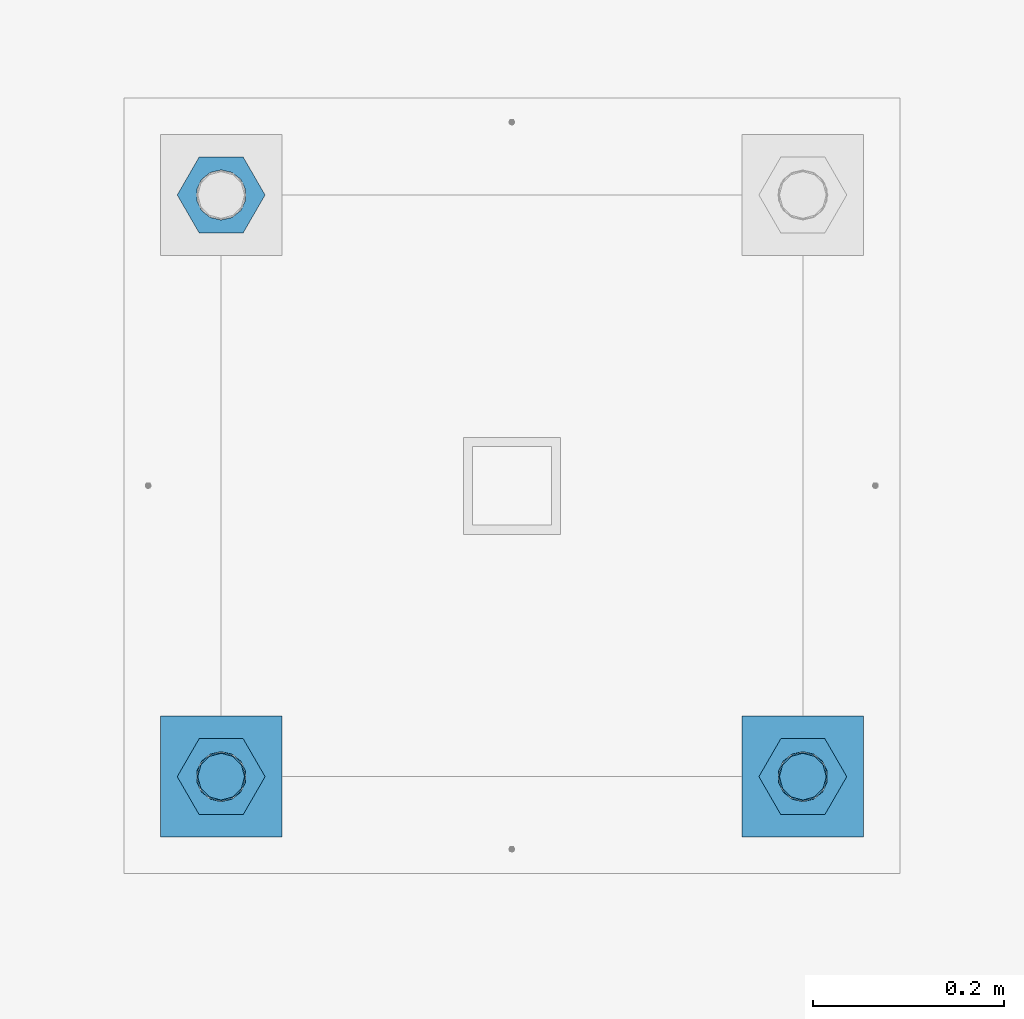
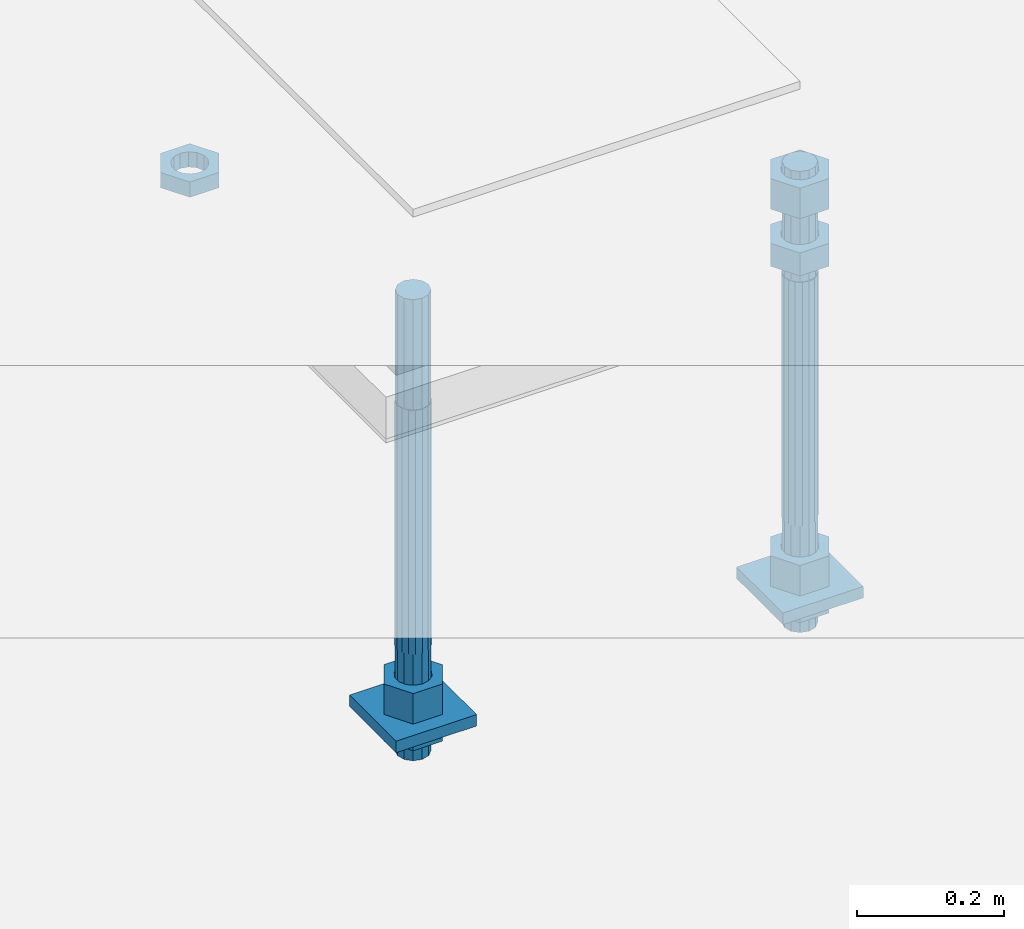
# One storey, part 2743 of 3843: 11 beams, 1 element without a shape of its own.
"""IFC2X3 building model written with IfcOpenShell, lengths in millimetres."""

from ifc_helpers import new_model, si_unit, frame, origin_with_axes, place, context, subcontext, project, spatial, faceted_brep, material, type_object, element, aggregate, save


model = new_model("IFC2X3")

# Units and contexts
model_context = context("Model", 3, precision=1e-05, world=origin_with_axes())
body_context = subcontext(model_context, "Body", "Model", "MODEL_VIEW")
ifc_project = project(units=[si_unit("LENGTHUNIT", "METRE", prefix="MILLI"), si_unit("AREAUNIT", "SQUARE_METRE"), si_unit("VOLUMEUNIT", "CUBIC_METRE"), si_unit("MASSUNIT", "GRAM", prefix="KILO"), si_unit("TIMEUNIT", "SECOND"), si_unit("PLANEANGLEUNIT", "RADIAN"), si_unit("SOLIDANGLEUNIT", "STERADIAN"), si_unit("THERMODYNAMICTEMPERATUREUNIT", "DEGREE_CELSIUS"), si_unit("LUMINOUSINTENSITYUNIT", "LUMEN")], contexts=[model_context])

# Site, building, storey
site_placement = place(None, origin_with_axes())
site = spatial("IfcSite", under=ifc_project, at=site_placement, CompositionType="ELEMENT")
building_placement = place(site_placement, origin_with_axes())
building = spatial("IfcBuilding", under=site, at=building_placement, Name="Undefined", CompositionType="ELEMENT")
storey_placement = place(building_placement, origin_with_axes())
storey = spatial("IfcBuildingStorey", under=building, at=storey_placement, Name="Undefined", CompositionType="ELEMENT", Elevation=0.0)

# Assembly, beams
assembly_placement = place(storey_placement, origin_with_axes())
assembly = element("IfcElementAssembly", 1, at=assembly_placement, inside=storey, Name="TEMPLATE", AssemblyPlace="NOTDEFINED", PredefinedType="RIGID_FRAME")
ifc_material_1 = material(Name="STEEL/A36")
beam_type_1 = type_object("IfcBeamType", PredefinedType="NOTDEFINED")
beam_1_placement = place(assembly_placement, frame((111734.6, 41503.6000015259, 29244.925), z_axis=(1.0, 0.0, 0.0), x_axis=(0.0, 1.0, 0.0)))
beam_1 = element("IfcBeam", 2, at=beam_1_placement, type_object=beam_type_1, material=ifc_material_1, Name="WASHER_PLATE", context=body_context, shape_type="Brep", body=[
    faceted_brep([(0.0, 9.52500000000146, -63.5), (0.0, 9.52500000000146, 63.5), (127.0, 9.52500000000146, 63.5), (127.0, 9.52500000000146, -63.5), (0.0, -9.52500000000146, 63.5), (127.0, -9.52500000000146, 63.5), (0.0, -9.52500000000146, -63.5), (127.0, -9.52500000000146, -63.5)], [[[0, 1, 2, 3]], [[1, 4, 5, 2]], [[4, 6, 7, 5]], [[6, 0, 3, 7]], [[5, 7, 3, 2]], [[6, 4, 1, 0]]]),
])
beam_2_placement = place(assembly_placement, frame((112344.2, 41503.6000015259, 29244.925), z_axis=(1.0, 0.0, 0.0), x_axis=(0.0, 1.0, 0.0)))
beam_2 = element("IfcBeam", 3, at=beam_2_placement, type_object=beam_type_1, material=ifc_material_1, Name="WASHER_PLATE", context=body_context, shape_type="Brep", body=[
    faceted_brep([(0.0, 9.52500000000146, -63.5), (0.0, 9.52500000000146, 63.5), (127.0, 9.52500000000146, 63.5), (127.0, 9.52500000000146, -63.5), (0.0, -9.52500000000146, 63.5), (127.0, -9.52500000000146, 63.5), (0.0, -9.52500000000146, -63.5), (127.0, -9.52500000000146, -63.5)], [[[0, 1, 2, 3]], [[1, 4, 5, 2]], [[4, 6, 7, 5]], [[6, 0, 3, 7]], [[5, 7, 3, 2]], [[6, 4, 1, 0]]]),
])
beam_type_2 = type_object("IfcBeamType", Name="2_HALF_NUT", PredefinedType="NOTDEFINED")
beam_3_placement = place(assembly_placement, frame((111734.6, 42176.7000015259, 29787.85), z_axis=(0.0, 1.0, 0.0), x_axis=(0.0, 0.0, -1.0)))
beam_3 = element("IfcBeam", 4, at=beam_3_placement, type_object=beam_type_2, material=ifc_material_1, Name="NUT", ObjectType="2_HALF_NUT", context=body_context, shape_type="Brep", body=[
    faceted_brep([(0.0, -46.0369987487793, 0.0), (0.0, -23.0184993743896, -39.869213104248), (25.4000000000015, -23.0184993743896, -39.869213104248), (25.4000000000015, -46.0369987487793, 0.0), (0.0, 23.0184993743896, -39.869213104248), (25.4000000000015, 23.0184993743896, -39.869213104248), (0.0, 46.0369987487793, 0.0), (25.4000000000015, 46.0369987487793, 0.0), (0.0, 23.0184993743896, 39.869213104248), (25.4000000000015, 23.0184993743896, 39.869213104248), (0.0, -23.0184993743896, 39.869213104248), (25.4000000000015, -23.0184993743896, 39.869213104248), (0.0, 0.0, 26.1940002441406), (0.0, 11.3650617044477, 23.5999013092805), (25.4000000000015, 11.3650617044477, 23.5999013092805), (25.4000000000015, 0.0, 26.1940002441406), (0.0, 20.4791109456419, 16.3316083006721), (25.4000000000015, 20.4791109456419, 16.3316083006721), (0.0, 25.5370200498292, 5.82867859874386), (25.4000000000015, 25.5370200498292, 5.82867859874386), (0.0, 25.5370200498292, -5.82867859874386), (25.4000000000015, 25.5370200498292, -5.82867859874386), (0.0, 20.4791109456419, -16.3316083006721), (25.4000000000015, 20.4791109456419, -16.3316083006721), (0.0, 11.3650617044477, -23.5999013092805), (25.4000000000015, 11.3650617044477, -23.5999013092805), (0.0, 0.0, -26.1940002441406), (25.4000000000015, 0.0, -26.1940002441406), (0.0, -11.3650617044477, -23.5999013092805), (25.4000000000015, -11.3650617044477, -23.5999013092805), (0.0, -20.4791109456419, -16.3316083006721), (25.4000000000015, -20.4791109456419, -16.3316083006721), (0.0, -25.5370200498292, -5.82867859874386), (25.4000000000015, -25.5370200498292, -5.82867859874386), (0.0, -25.5370200498292, 5.82867859874386), (25.4000000000015, -25.5370200498292, 5.82867859874386), (0.0, -20.4791109456419, 16.3316083006721), (25.4000000000015, -20.4791109456419, 16.3316083006721), (0.0, -11.3650617044477, 23.5999013092805), (25.4000000000015, -11.3650617044477, 23.5999013092805)], [[[0, 1, 2, 3]], [[1, 4, 5, 2]], [[4, 6, 7, 5]], [[6, 8, 9, 7]], [[8, 10, 11, 9]], [[10, 0, 3, 11]], [[12, 13, 14, 15]], [[13, 16, 17, 14]], [[16, 18, 19, 17]], [[18, 20, 21, 19]], [[20, 22, 23, 21]], [[22, 24, 25, 23]], [[24, 26, 27, 25]], [[26, 28, 29, 27]], [[28, 30, 31, 29]], [[30, 32, 33, 31]], [[32, 34, 35, 33]], [[34, 36, 37, 35]], [[36, 38, 39, 37]], [[38, 12, 15, 39]], [[5, 7, 9, 11, 3, 2], [17, 19, 21, 23, 25, 27, 29, 31, 33, 35, 37, 39, 15, 14]], [[10, 8, 6, 4, 1, 0], [38, 36, 34, 32, 30, 28, 26, 24, 22, 20, 18, 16, 13, 12]]]),
])
beam_4_placement = place(assembly_placement, frame((111734.6, 41567.1000015259, 29235.4), z_axis=(0.0, 1.0, 0.0), x_axis=(0.0, 0.0, -1.0)))
beam_4 = element("IfcBeam", 5, at=beam_4_placement, type_object=beam_type_2, material=ifc_material_1, Name="NUT", ObjectType="2_HALF_NUT", context=body_context, shape_type="Brep", body=[
    faceted_brep([(0.0, -46.0369987487793, 0.0), (0.0, -23.0184993743896, -39.869213104248), (25.4000000000015, -23.0184993743896, -39.869213104248), (25.4000000000015, -46.0369987487793, 0.0), (0.0, 23.0184993743896, -39.869213104248), (25.4000000000015, 23.0184993743896, -39.869213104248), (0.0, 46.0369987487793, 0.0), (25.4000000000015, 46.0369987487793, 0.0), (0.0, 23.0184993743896, 39.869213104248), (25.4000000000015, 23.0184993743896, 39.869213104248), (0.0, -23.0184993743896, 39.869213104248), (25.4000000000015, -23.0184993743896, 39.869213104248), (0.0, 0.0, 26.1940002441406), (0.0, 11.3650617044477, 23.5999013092805), (25.4000000000015, 11.3650617044477, 23.5999013092805), (25.4000000000015, 0.0, 26.1940002441406), (0.0, 20.4791109456419, 16.3316083006721), (25.4000000000015, 20.4791109456419, 16.3316083006721), (0.0, 25.5370200498292, 5.82867859874386), (25.4000000000015, 25.5370200498292, 5.82867859874386), (0.0, 25.5370200498292, -5.82867859874386), (25.4000000000015, 25.5370200498292, -5.82867859874386), (0.0, 20.4791109456419, -16.3316083006721), (25.4000000000015, 20.4791109456419, -16.3316083006721), (0.0, 11.3650617044477, -23.5999013092805), (25.4000000000015, 11.3650617044477, -23.5999013092805), (0.0, 0.0, -26.1940002441406), (25.4000000000015, 0.0, -26.1940002441406), (0.0, -11.3650617044477, -23.5999013092805), (25.4000000000015, -11.3650617044477, -23.5999013092805), (0.0, -20.4791109456419, -16.3316083006721), (25.4000000000015, -20.4791109456419, -16.3316083006721), (0.0, -25.5370200498292, -5.82867859874386), (25.4000000000015, -25.5370200498292, -5.82867859874386), (0.0, -25.5370200498292, 5.82867859874386), (25.4000000000015, -25.5370200498292, 5.82867859874386), (0.0, -20.4791109456419, 16.3316083006721), (25.4000000000015, -20.4791109456419, 16.3316083006721), (0.0, -11.3650617044477, 23.5999013092805), (25.4000000000015, -11.3650617044477, 23.5999013092805)], [[[0, 1, 2, 3]], [[1, 4, 5, 2]], [[4, 6, 7, 5]], [[6, 8, 9, 7]], [[8, 10, 11, 9]], [[10, 0, 3, 11]], [[12, 13, 14, 15]], [[13, 16, 17, 14]], [[16, 18, 19, 17]], [[18, 20, 21, 19]], [[20, 22, 23, 21]], [[22, 24, 25, 23]], [[24, 26, 27, 25]], [[26, 28, 29, 27]], [[28, 30, 31, 29]], [[30, 32, 33, 31]], [[32, 34, 35, 33]], [[34, 36, 37, 35]], [[36, 38, 39, 37]], [[38, 12, 15, 39]], [[5, 7, 9, 11, 3, 2], [17, 19, 21, 23, 25, 27, 29, 31, 33, 35, 37, 39, 15, 14]], [[10, 8, 6, 4, 1, 0], [38, 36, 34, 32, 30, 28, 26, 24, 22, 20, 18, 16, 13, 12]]]),
])
beam_5_placement = place(assembly_placement, frame((112344.2, 41567.1000015259, 29235.4), z_axis=(0.0, 1.0, 0.0), x_axis=(0.0, 0.0, -1.0)))
beam_5 = element("IfcBeam", 6, at=beam_5_placement, type_object=beam_type_2, material=ifc_material_1, Name="NUT", ObjectType="2_HALF_NUT", context=body_context, shape_type="Brep", body=[
    faceted_brep([(0.0, -46.0369987487793, 0.0), (0.0, -23.0184993743896, -39.869213104248), (25.4000000000015, -23.0184993743896, -39.869213104248), (25.4000000000015, -46.0369987487793, 0.0), (0.0, 23.0184993743896, -39.869213104248), (25.4000000000015, 23.0184993743896, -39.869213104248), (0.0, 46.0369987487793, 0.0), (25.4000000000015, 46.0369987487793, 0.0), (0.0, 23.0184993743896, 39.869213104248), (25.4000000000015, 23.0184993743896, 39.869213104248), (0.0, -23.0184993743896, 39.869213104248), (25.4000000000015, -23.0184993743896, 39.869213104248), (0.0, 0.0, 26.1940002441406), (0.0, 11.3650617044477, 23.5999013092805), (25.4000000000015, 11.3650617044477, 23.5999013092805), (25.4000000000015, 0.0, 26.1940002441406), (0.0, 20.4791109456419, 16.3316083006721), (25.4000000000015, 20.4791109456419, 16.3316083006721), (0.0, 25.5370200498292, 5.82867859874386), (25.4000000000015, 25.5370200498292, 5.82867859874386), (0.0, 25.5370200498292, -5.82867859874386), (25.4000000000015, 25.5370200498292, -5.82867859874386), (0.0, 20.4791109456419, -16.3316083006721), (25.4000000000015, 20.4791109456419, -16.3316083006721), (0.0, 11.3650617044477, -23.5999013092805), (25.4000000000015, 11.3650617044477, -23.5999013092805), (0.0, 0.0, -26.1940002441406), (25.4000000000015, 0.0, -26.1940002441406), (0.0, -11.3650617044477, -23.5999013092805), (25.4000000000015, -11.3650617044477, -23.5999013092805), (0.0, -20.4791109456419, -16.3316083006721), (25.4000000000015, -20.4791109456419, -16.3316083006721), (0.0, -25.5370200498292, -5.82867859874386), (25.4000000000015, -25.5370200498292, -5.82867859874386), (0.0, -25.5370200498292, 5.82867859874386), (25.4000000000015, -25.5370200498292, 5.82867859874386), (0.0, -20.4791109456419, 16.3316083006721), (25.4000000000015, -20.4791109456419, 16.3316083006721), (0.0, -11.3650617044477, 23.5999013092805), (25.4000000000015, -11.3650617044477, 23.5999013092805)], [[[0, 1, 2, 3]], [[1, 4, 5, 2]], [[4, 6, 7, 5]], [[6, 8, 9, 7]], [[8, 10, 11, 9]], [[10, 0, 3, 11]], [[12, 13, 14, 15]], [[13, 16, 17, 14]], [[16, 18, 19, 17]], [[18, 20, 21, 19]], [[20, 22, 23, 21]], [[22, 24, 25, 23]], [[24, 26, 27, 25]], [[26, 28, 29, 27]], [[28, 30, 31, 29]], [[30, 32, 33, 31]], [[32, 34, 35, 33]], [[34, 36, 37, 35]], [[36, 38, 39, 37]], [[38, 12, 15, 39]], [[5, 7, 9, 11, 3, 2], [17, 19, 21, 23, 25, 27, 29, 31, 33, 35, 37, 39, 15, 14]], [[10, 8, 6, 4, 1, 0], [38, 36, 34, 32, 30, 28, 26, 24, 22, 20, 18, 16, 13, 12]]]),
])
beam_type_3 = type_object("IfcBeamType", Name="2_HEAVY_HEX_NUT", PredefinedType="NOTDEFINED")
beam_6_placement = place(assembly_placement, frame((111734.6, 41567.1000015259, 29305.25), z_axis=(0.0, 1.0, 0.0), x_axis=(0.0, 0.0, -1.0)))
beam_6 = element("IfcBeam", 7, at=beam_6_placement, type_object=beam_type_3, material=ifc_material_1, Name="NUT", ObjectType="2_HEAVY_HEX_NUT", context=body_context, shape_type="Brep", body=[
    faceted_brep([(0.0, -46.0369987487793, 0.0), (0.0, -23.0184993743896, -39.869213104248), (50.7999999999993, -23.0184993743896, -39.869213104248), (50.7999999999993, -46.0369987487793, 0.0), (0.0, 23.0184993743896, -39.869213104248), (50.7999999999993, 23.0184993743896, -39.869213104248), (0.0, 46.0369987487793, 0.0), (50.7999999999993, 46.0369987487793, 0.0), (0.0, 23.0184993743896, 39.869213104248), (50.7999999999993, 23.0184993743896, 39.869213104248), (0.0, -23.0184993743896, 39.869213104248), (50.7999999999993, -23.0184993743896, 39.869213104248), (0.0, 0.0, 26.1940002441406), (0.0, 11.3650617044477, 23.5999013092805), (50.7999999999993, 11.3650617044477, 23.5999013092805), (50.7999999999993, 0.0, 26.1940002441406), (0.0, 20.4791109456419, 16.3316083006721), (50.7999999999993, 20.4791109456419, 16.3316083006721), (0.0, 25.5370200498292, 5.82867859874386), (50.7999999999993, 25.5370200498292, 5.82867859874386), (0.0, 25.5370200498292, -5.82867859874386), (50.7999999999993, 25.5370200498292, -5.82867859874386), (0.0, 20.4791109456419, -16.3316083006721), (50.7999999999993, 20.4791109456419, -16.3316083006721), (0.0, 11.3650617044477, -23.5999013092805), (50.7999999999993, 11.3650617044477, -23.5999013092805), (0.0, 0.0, -26.1940002441406), (50.7999999999993, 0.0, -26.1940002441406), (0.0, -11.3650617044477, -23.5999013092805), (50.7999999999993, -11.3650617044477, -23.5999013092805), (0.0, -20.4791109456419, -16.3316083006721), (50.7999999999993, -20.4791109456419, -16.3316083006721), (0.0, -25.5370200498292, -5.82867859874386), (50.7999999999993, -25.5370200498292, -5.82867859874386), (0.0, -25.5370200498292, 5.82867859874386), (50.7999999999993, -25.5370200498292, 5.82867859874386), (0.0, -20.4791109456419, 16.3316083006721), (50.7999999999993, -20.4791109456419, 16.3316083006721), (0.0, -11.3650617044477, 23.5999013092805), (50.7999999999993, -11.3650617044477, 23.5999013092805)], [[[0, 1, 2, 3]], [[1, 4, 5, 2]], [[4, 6, 7, 5]], [[6, 8, 9, 7]], [[8, 10, 11, 9]], [[10, 0, 3, 11]], [[12, 13, 14, 15]], [[13, 16, 17, 14]], [[16, 18, 19, 17]], [[18, 20, 21, 19]], [[20, 22, 23, 21]], [[22, 24, 25, 23]], [[24, 26, 27, 25]], [[26, 28, 29, 27]], [[28, 30, 31, 29]], [[30, 32, 33, 31]], [[32, 34, 35, 33]], [[34, 36, 37, 35]], [[36, 38, 39, 37]], [[38, 12, 15, 39]], [[5, 7, 9, 11, 3, 2], [17, 19, 21, 23, 25, 27, 29, 31, 33, 35, 37, 39, 15, 14]], [[10, 8, 6, 4, 1, 0], [38, 36, 34, 32, 30, 28, 26, 24, 22, 20, 18, 16, 13, 12]]]),
])
beam_7_placement = place(assembly_placement, frame((112344.2, 41567.1000015259, 29825.95), z_axis=(0.0, 1.0, 0.0), x_axis=(0.0, 0.0, -1.0)))
beam_7 = element("IfcBeam", 8, at=beam_7_placement, type_object=beam_type_3, material=ifc_material_1, Name="NUT", ObjectType="2_HEAVY_HEX_NUT", context=body_context, shape_type="Brep", body=[
    faceted_brep([(0.0, -46.0369987487793, 0.0), (0.0, -23.0184993743896, -39.869213104248), (38.0999999999985, -23.0184993743896, -39.869213104248), (38.0999999999985, -46.0369987487793, 0.0), (0.0, 23.0184993743896, -39.869213104248), (38.0999999999985, 23.0184993743896, -39.869213104248), (0.0, 46.0369987487793, 0.0), (38.0999999999985, 46.0369987487793, 0.0), (0.0, 23.0184993743896, 39.869213104248), (38.0999999999985, 23.0184993743896, 39.869213104248), (0.0, -23.0184993743896, 39.869213104248), (38.0999999999985, -23.0184993743896, 39.869213104248), (0.0, 0.0, 26.1940002441406), (0.0, 11.3650617044477, 23.5999013092805), (38.0999999999985, 11.3650617044477, 23.5999013092805), (38.0999999999985, 0.0, 26.1940002441406), (0.0, 20.4791109456419, 16.3316083006721), (38.0999999999985, 20.4791109456419, 16.3316083006721), (0.0, 25.5370200498292, 5.82867859874386), (38.0999999999985, 25.5370200498292, 5.82867859874386), (0.0, 25.5370200498292, -5.82867859874386), (38.0999999999985, 25.5370200498292, -5.82867859874386), (0.0, 20.4791109456419, -16.3316083006721), (38.0999999999985, 20.4791109456419, -16.3316083006721), (0.0, 11.3650617044477, -23.5999013092805), (38.0999999999985, 11.3650617044477, -23.5999013092805), (0.0, 0.0, -26.1940002441406), (38.0999999999985, 0.0, -26.1940002441406), (0.0, -11.3650617044477, -23.5999013092805), (38.0999999999985, -11.3650617044477, -23.5999013092805), (0.0, -20.4791109456419, -16.3316083006721), (38.0999999999985, -20.4791109456419, -16.3316083006721), (0.0, -25.5370200498292, -5.82867859874386), (38.0999999999985, -25.5370200498292, -5.82867859874386), (0.0, -25.5370200498292, 5.82867859874386), (38.0999999999985, -25.5370200498292, 5.82867859874386), (0.0, -20.4791109456419, 16.3316083006721), (38.0999999999985, -20.4791109456419, 16.3316083006721), (0.0, -11.3650617044477, 23.5999013092805), (38.0999999999985, -11.3650617044477, 23.5999013092805)], [[[0, 1, 2, 3]], [[1, 4, 5, 2]], [[4, 6, 7, 5]], [[6, 8, 9, 7]], [[8, 10, 11, 9]], [[10, 0, 3, 11]], [[12, 13, 14, 15]], [[13, 16, 17, 14]], [[16, 18, 19, 17]], [[18, 20, 21, 19]], [[20, 22, 23, 21]], [[22, 24, 25, 23]], [[24, 26, 27, 25]], [[26, 28, 29, 27]], [[28, 30, 31, 29]], [[30, 32, 33, 31]], [[32, 34, 35, 33]], [[34, 36, 37, 35]], [[36, 38, 39, 37]], [[38, 12, 15, 39]], [[5, 7, 9, 11, 3, 2], [17, 19, 21, 23, 25, 27, 29, 31, 33, 35, 37, 39, 15, 14]], [[10, 8, 6, 4, 1, 0], [38, 36, 34, 32, 30, 28, 26, 24, 22, 20, 18, 16, 13, 12]]]),
])
beam_8_placement = place(assembly_placement, frame((112344.2, 41567.1000015259, 29933.9), z_axis=(0.0, 1.0, 0.0), x_axis=(0.0, 0.0, -1.0)))
beam_8 = element("IfcBeam", 9, at=beam_8_placement, type_object=beam_type_3, material=ifc_material_1, Name="NUT", ObjectType="2_HEAVY_HEX_NUT", context=body_context, shape_type="Brep", body=[
    faceted_brep([(0.0, -46.0369987487793, 0.0), (0.0, -23.0184993743896, -39.869213104248), (50.7999999999993, -23.0184993743896, -39.869213104248), (50.7999999999993, -46.0369987487793, 0.0), (0.0, 23.0184993743896, -39.869213104248), (50.7999999999993, 23.0184993743896, -39.869213104248), (0.0, 46.0369987487793, 0.0), (50.7999999999993, 46.0369987487793, 0.0), (0.0, 23.0184993743896, 39.869213104248), (50.7999999999993, 23.0184993743896, 39.869213104248), (0.0, -23.0184993743896, 39.869213104248), (50.7999999999993, -23.0184993743896, 39.869213104248), (0.0, 0.0, 26.1940002441406), (0.0, 11.3650617044477, 23.5999013092805), (50.7999999999993, 11.3650617044477, 23.5999013092805), (50.7999999999993, 0.0, 26.1940002441406), (0.0, 20.4791109456419, 16.3316083006721), (50.7999999999993, 20.4791109456419, 16.3316083006721), (0.0, 25.5370200498292, 5.82867859874386), (50.7999999999993, 25.5370200498292, 5.82867859874386), (0.0, 25.5370200498292, -5.82867859874386), (50.7999999999993, 25.5370200498292, -5.82867859874386), (0.0, 20.4791109456419, -16.3316083006721), (50.7999999999993, 20.4791109456419, -16.3316083006721), (0.0, 11.3650617044477, -23.5999013092805), (50.7999999999993, 11.3650617044477, -23.5999013092805), (0.0, 0.0, -26.1940002441406), (50.7999999999993, 0.0, -26.1940002441406), (0.0, -11.3650617044477, -23.5999013092805), (50.7999999999993, -11.3650617044477, -23.5999013092805), (0.0, -20.4791109456419, -16.3316083006721), (50.7999999999993, -20.4791109456419, -16.3316083006721), (0.0, -25.5370200498292, -5.82867859874386), (50.7999999999993, -25.5370200498292, -5.82867859874386), (0.0, -25.5370200498292, 5.82867859874386), (50.7999999999993, -25.5370200498292, 5.82867859874386), (0.0, -20.4791109456419, 16.3316083006721), (50.7999999999993, -20.4791109456419, 16.3316083006721), (0.0, -11.3650617044477, 23.5999013092805), (50.7999999999993, -11.3650617044477, 23.5999013092805)], [[[0, 1, 2, 3]], [[1, 4, 5, 2]], [[4, 6, 7, 5]], [[6, 8, 9, 7]], [[8, 10, 11, 9]], [[10, 0, 3, 11]], [[12, 13, 14, 15]], [[13, 16, 17, 14]], [[16, 18, 19, 17]], [[18, 20, 21, 19]], [[20, 22, 23, 21]], [[22, 24, 25, 23]], [[24, 26, 27, 25]], [[26, 28, 29, 27]], [[28, 30, 31, 29]], [[30, 32, 33, 31]], [[32, 34, 35, 33]], [[34, 36, 37, 35]], [[36, 38, 39, 37]], [[38, 12, 15, 39]], [[5, 7, 9, 11, 3, 2], [17, 19, 21, 23, 25, 27, 29, 31, 33, 35, 37, 39, 15, 14]], [[10, 8, 6, 4, 1, 0], [38, 36, 34, 32, 30, 28, 26, 24, 22, 20, 18, 16, 13, 12]]]),
])
beam_9_placement = place(assembly_placement, frame((112344.2, 41567.1000015259, 29305.25), z_axis=(0.0, 1.0, 0.0), x_axis=(0.0, 0.0, -1.0)))
beam_9 = element("IfcBeam", 10, at=beam_9_placement, type_object=beam_type_3, material=ifc_material_1, Name="NUT", ObjectType="2_HEAVY_HEX_NUT", context=body_context, shape_type="Brep", body=[
    faceted_brep([(0.0, -46.0369987487793, 0.0), (0.0, -23.0184993743896, -39.869213104248), (50.7999999999993, -23.0184993743896, -39.869213104248), (50.7999999999993, -46.0369987487793, 0.0), (0.0, 23.0184993743896, -39.869213104248), (50.7999999999993, 23.0184993743896, -39.869213104248), (0.0, 46.0369987487793, 0.0), (50.7999999999993, 46.0369987487793, 0.0), (0.0, 23.0184993743896, 39.869213104248), (50.7999999999993, 23.0184993743896, 39.869213104248), (0.0, -23.0184993743896, 39.869213104248), (50.7999999999993, -23.0184993743896, 39.869213104248), (0.0, 0.0, 26.1940002441406), (0.0, 11.3650617044477, 23.5999013092805), (50.7999999999993, 11.3650617044477, 23.5999013092805), (50.7999999999993, 0.0, 26.1940002441406), (0.0, 20.4791109456419, 16.3316083006721), (50.7999999999993, 20.4791109456419, 16.3316083006721), (0.0, 25.5370200498292, 5.82867859874386), (50.7999999999993, 25.5370200498292, 5.82867859874386), (0.0, 25.5370200498292, -5.82867859874386), (50.7999999999993, 25.5370200498292, -5.82867859874386), (0.0, 20.4791109456419, -16.3316083006721), (50.7999999999993, 20.4791109456419, -16.3316083006721), (0.0, 11.3650617044477, -23.5999013092805), (50.7999999999993, 11.3650617044477, -23.5999013092805), (0.0, 0.0, -26.1940002441406), (50.7999999999993, 0.0, -26.1940002441406), (0.0, -11.3650617044477, -23.5999013092805), (50.7999999999993, -11.3650617044477, -23.5999013092805), (0.0, -20.4791109456419, -16.3316083006721), (50.7999999999993, -20.4791109456419, -16.3316083006721), (0.0, -25.5370200498292, -5.82867859874386), (50.7999999999993, -25.5370200498292, -5.82867859874386), (0.0, -25.5370200498292, 5.82867859874386), (50.7999999999993, -25.5370200498292, 5.82867859874386), (0.0, -20.4791109456419, 16.3316083006721), (50.7999999999993, -20.4791109456419, 16.3316083006721), (0.0, -11.3650617044477, 23.5999013092805), (50.7999999999993, -11.3650617044477, 23.5999013092805)], [[[0, 1, 2, 3]], [[1, 4, 5, 2]], [[4, 6, 7, 5]], [[6, 8, 9, 7]], [[8, 10, 11, 9]], [[10, 0, 3, 11]], [[12, 13, 14, 15]], [[13, 16, 17, 14]], [[16, 18, 19, 17]], [[18, 20, 21, 19]], [[20, 22, 23, 21]], [[22, 24, 25, 23]], [[24, 26, 27, 25]], [[26, 28, 29, 27]], [[28, 30, 31, 29]], [[30, 32, 33, 31]], [[32, 34, 35, 33]], [[34, 36, 37, 35]], [[36, 38, 39, 37]], [[38, 12, 15, 39]], [[5, 7, 9, 11, 3, 2], [17, 19, 21, 23, 25, 27, 29, 31, 33, 35, 37, 39, 15, 14]], [[10, 8, 6, 4, 1, 0], [38, 36, 34, 32, 30, 28, 26, 24, 22, 20, 18, 16, 13, 12]]]),
])
ifc_material_2 = material()
beam_type_4 = type_object("IfcBeamType", PredefinedType="NOTDEFINED")
beam_10_placement = place(assembly_placement, frame((112344.2, 41567.1000015259, 29762.45), z_axis=(0.0, 1.0, 0.0), x_axis=(0.0, 0.0, -1.0)))
beam_10 = element("IfcBeam", 11, at=beam_10_placement, type_object=beam_type_4, material=ifc_material_2, Name="ANCHOR_ROD", context=body_context, shape_type="Brep", body=[
    faceted_brep([(-184.150000000001, -21.217622392709, 12.25), (-184.150000000001, -12.2499999999854, 21.2176223927163), (-184.150000000001, 1.45519152283669e-11, 24.5), (-184.150000000001, 12.2500000000146, 21.2176223927163), (-184.150000000001, 21.2176223927381, 12.25), (-184.150000000001, 24.5000000000146, 0.0), (-184.150000000001, 21.2176223927381, -12.25), (-184.150000000001, 12.2500000000146, -21.2176223927163), (-184.150000000001, 1.45519152283669e-11, -24.5), (-184.150000000001, -12.2499999999854, -21.2176223927163), (-184.150000000001, -21.217622392709, -12.25), (-184.150000000001, -24.4999999999854, 0.0), (0.0, 24.5000000000146, 0.0), (0.0, 21.2176223927381, -12.25), (0.0, 12.2500000000146, -21.2176223927163), (0.0, 1.45519152283669e-11, -24.5), (0.0, -12.2499999999854, -21.2176223927163), (0.0, -21.217622392709, -12.25), (0.0, -24.4999999999854, 0.0), (0.0, -21.217622392709, 12.25), (0.0, -12.2499999999854, 21.2176223927163), (0.0, 1.45519152283669e-11, 24.5), (0.0, 12.2500000000146, 21.2176223927163), (0.0, 21.2176223927381, 12.25), (0.0, -23.4665401257807, 9.72015918207035), (0.0, -17.9605122421344, 17.9605122421417), (0.0, -9.72015918207762, 23.466540125788), (0.0, 0.0, 25.4000000000015), (0.0, 9.72015918207762, 23.466540125788), (0.0, 17.9605122421344, 17.9605122421417), (0.0, 23.4665401257807, 9.72015918207035), (0.0, 25.3999996185303, 0.0), (0.0, 23.4665401257807, -9.72015918207035), (0.0, 17.9605122421344, -17.9605122421417), (0.0, 9.72015918207762, -23.466540125788), (0.0, 0.0, -25.4000000000015), (0.0, -9.72015918207762, -23.466540125788), (0.0, -17.9605122421344, -17.9605122421417), (0.0, -23.4665401257807, -9.72015918207035), (0.0, -25.3999996185303, 0.0), (406.399999999998, -25.3999999999942, 0.0), (406.399999999998, -23.4665401257807, 9.72015918207035), (406.399999999998, -17.9605122421344, 17.9605122421417), (406.399999999998, -9.72015918207762, 23.466540125788), (406.399999999998, 0.0, 25.4000000000015), (406.399999999998, 9.72015918207762, 23.466540125788), (406.399999999998, 17.9605122421344, 17.9605122421417), (406.399999999998, 23.4665401257807, 9.72015918207035), (406.399999999998, 25.3999999999942, 0.0), (406.399999999998, 23.4665401257807, -9.72015918207035), (406.399999999998, 17.9605122421344, -17.9605122421417), (406.399999999998, 9.72015918207762, -23.466540125788), (406.399999999998, 0.0, -25.4000000000015), (406.399999999998, -9.72015918207762, -23.466540125788), (406.399999999998, -17.9605122421344, -17.9605122421417), (406.399999999998, -23.4665401257807, -9.72015918207035), (406.399999999998, -12.2499999999854, 21.2176223927163), (406.399999999998, 1.45519152283669e-11, 24.5), (406.399999999998, 12.2500000000146, 21.2176223927163), (406.399999999998, 21.2176223927381, 12.25), (406.399999999998, 24.5000000000146, 0.0), (406.399999999998, 21.2176223927381, -12.25), (406.399999999998, 12.2500000000146, -21.2176223927163), (406.399999999998, 1.45519152283669e-11, -24.5), (406.399999999998, -12.2499999999854, -21.2176223927163), (406.399999999998, -21.217622392709, -12.25), (406.399999999998, -24.4999999999854, 0.0), (406.399999999998, -21.217622392709, 12.25), (584.200000000001, -12.2499999999854, -21.2176223927163), (584.200000000001, 1.45519152283669e-11, -24.5), (584.200000000001, 12.2500000000146, -21.2176223927163), (584.200000000001, 21.2176223927381, -12.25), (584.200000000001, 24.5000000000146, 0.0), (584.200000000001, 21.2176223927381, 12.25), (584.200000000001, 12.2500000000146, 21.2176223927163), (584.200000000001, 1.45519152283669e-11, 24.5), (584.200000000001, -12.2499999999854, 21.2176223927163), (584.200000000001, -21.217622392709, 12.25), (584.200000000001, -24.4999999999854, 0.0), (584.200000000001, -21.217622392709, -12.25)], [[[0, 1, 2, 3, 4, 5, 6, 7, 8, 9, 10, 11]], [[6, 5, 12, 13]], [[7, 6, 13, 14]], [[8, 7, 14, 15]], [[9, 8, 15, 16]], [[10, 9, 16, 17]], [[11, 10, 17, 18]], [[0, 11, 18, 19]], [[1, 0, 19, 20]], [[2, 1, 20, 21]], [[3, 2, 21, 22]], [[4, 3, 22, 23]], [[5, 4, 23, 12]], [[24, 25, 26, 27, 28, 29, 30, 31, 32, 33, 34, 35, 36, 37, 38, 39], [22, 21, 20, 19, 18, 17, 16, 15, 14, 13, 12, 23]], [[24, 39, 40, 41]], [[25, 24, 41, 42]], [[26, 25, 42, 43]], [[27, 26, 43, 44]], [[28, 27, 44, 45]], [[29, 28, 45, 46]], [[30, 29, 46, 47]], [[31, 30, 47, 48]], [[32, 31, 48, 49]], [[33, 32, 49, 50]], [[34, 33, 50, 51]], [[35, 34, 51, 52]], [[36, 35, 52, 53]], [[37, 36, 53, 54]], [[38, 37, 54, 55]], [[39, 38, 55, 40]], [[54, 53, 52, 51, 50, 49, 48, 47, 46, 45, 44, 43, 42, 41, 40, 55], [56, 57, 58, 59, 60, 61, 62, 63, 64, 65, 66, 67]], [[68, 69, 70, 71, 72, 73, 74, 75, 76, 77, 78, 79]], [[76, 75, 57, 56]], [[77, 76, 56, 67]], [[78, 77, 67, 66]], [[79, 78, 66, 65]], [[68, 79, 65, 64]], [[69, 68, 64, 63]], [[70, 69, 63, 62]], [[71, 70, 62, 61]], [[72, 71, 61, 60]], [[73, 72, 60, 59]], [[74, 73, 59, 58]], [[75, 74, 58, 57]]]),
])
beam_11_placement = place(assembly_placement, frame((111734.6, 41567.1000015259, 29762.45), z_axis=(0.0, 1.0, 0.0), x_axis=(0.0, 0.0, -1.0)))
beam_11 = element("IfcBeam", 12, at=beam_11_placement, type_object=beam_type_4, material=ifc_material_2, Name="ANCHOR_ROD", context=body_context, shape_type="Brep", body=[
    faceted_brep([(-184.150000000001, -21.217622392709, 12.25), (-184.150000000001, -12.2499999999854, 21.2176223927163), (-184.150000000001, 1.45519152283669e-11, 24.5), (-184.150000000001, 12.2500000000146, 21.2176223927163), (-184.150000000001, 21.2176223927381, 12.25), (-184.150000000001, 24.5000000000146, 0.0), (-184.150000000001, 21.2176223927381, -12.25), (-184.150000000001, 12.2500000000146, -21.2176223927163), (-184.150000000001, 1.45519152283669e-11, -24.5), (-184.150000000001, -12.2499999999854, -21.2176223927163), (-184.150000000001, -21.217622392709, -12.25), (-184.150000000001, -24.4999999999854, 0.0), (0.0, 24.5000000000146, 0.0), (0.0, 21.2176223927381, -12.25), (0.0, 12.2500000000146, -21.2176223927163), (0.0, 1.45519152283669e-11, -24.5), (0.0, -12.2499999999854, -21.2176223927163), (0.0, -21.217622392709, -12.25), (0.0, -24.4999999999854, 0.0), (0.0, -21.217622392709, 12.25), (0.0, -12.2499999999854, 21.2176223927163), (0.0, 1.45519152283669e-11, 24.5), (0.0, 12.2500000000146, 21.2176223927163), (0.0, 21.2176223927381, 12.25), (0.0, -23.4665401257807, 9.72015918207035), (0.0, -17.9605122421344, 17.9605122421417), (0.0, -9.72015918207762, 23.466540125788), (0.0, 0.0, 25.4000000000015), (0.0, 9.72015918207762, 23.466540125788), (0.0, 17.9605122421344, 17.9605122421417), (0.0, 23.4665401257807, 9.72015918207035), (0.0, 25.3999996185303, 0.0), (0.0, 23.4665401257807, -9.72015918207035), (0.0, 17.9605122421344, -17.9605122421417), (0.0, 9.72015918207762, -23.466540125788), (0.0, 0.0, -25.4000000000015), (0.0, -9.72015918207762, -23.466540125788), (0.0, -17.9605122421344, -17.9605122421417), (0.0, -23.4665401257807, -9.72015918207035), (0.0, -25.3999996185303, 0.0), (406.399999999998, -25.3999999999942, 0.0), (406.399999999998, -23.4665401257807, 9.72015918207035), (406.399999999998, -17.9605122421344, 17.9605122421417), (406.399999999998, -9.72015918207762, 23.466540125788), (406.399999999998, 0.0, 25.4000000000015), (406.399999999998, 9.72015918207762, 23.466540125788), (406.399999999998, 17.9605122421344, 17.9605122421417), (406.399999999998, 23.4665401257807, 9.72015918207035), (406.399999999998, 25.3999999999942, 0.0), (406.399999999998, 23.4665401257807, -9.72015918207035), (406.399999999998, 17.9605122421344, -17.9605122421417), (406.399999999998, 9.72015918207762, -23.466540125788), (406.399999999998, 0.0, -25.4000000000015), (406.399999999998, -9.72015918207762, -23.466540125788), (406.399999999998, -17.9605122421344, -17.9605122421417), (406.399999999998, -23.4665401257807, -9.72015918207035), (406.399999999998, -12.2499999999854, 21.2176223927163), (406.399999999998, 1.45519152283669e-11, 24.5), (406.399999999998, 12.2500000000146, 21.2176223927163), (406.399999999998, 21.2176223927381, 12.25), (406.399999999998, 24.5000000000146, 0.0), (406.399999999998, 21.2176223927381, -12.25), (406.399999999998, 12.2500000000146, -21.2176223927163), (406.399999999998, 1.45519152283669e-11, -24.5), (406.399999999998, -12.2499999999854, -21.2176223927163), (406.399999999998, -21.217622392709, -12.25), (406.399999999998, -24.4999999999854, 0.0), (406.399999999998, -21.217622392709, 12.25), (584.200000000001, -12.2499999999854, -21.2176223927163), (584.200000000001, 1.45519152283669e-11, -24.5), (584.200000000001, 12.2500000000146, -21.2176223927163), (584.200000000001, 21.2176223927381, -12.25), (584.200000000001, 24.5000000000146, 0.0), (584.200000000001, 21.2176223927381, 12.25), (584.200000000001, 12.2500000000146, 21.2176223927163), (584.200000000001, 1.45519152283669e-11, 24.5), (584.200000000001, -12.2499999999854, 21.2176223927163), (584.200000000001, -21.217622392709, 12.25), (584.200000000001, -24.4999999999854, 0.0), (584.200000000001, -21.217622392709, -12.25)], [[[0, 1, 2, 3, 4, 5, 6, 7, 8, 9, 10, 11]], [[6, 5, 12, 13]], [[7, 6, 13, 14]], [[8, 7, 14, 15]], [[9, 8, 15, 16]], [[10, 9, 16, 17]], [[11, 10, 17, 18]], [[0, 11, 18, 19]], [[1, 0, 19, 20]], [[2, 1, 20, 21]], [[3, 2, 21, 22]], [[4, 3, 22, 23]], [[5, 4, 23, 12]], [[24, 25, 26, 27, 28, 29, 30, 31, 32, 33, 34, 35, 36, 37, 38, 39], [22, 21, 20, 19, 18, 17, 16, 15, 14, 13, 12, 23]], [[24, 39, 40, 41]], [[25, 24, 41, 42]], [[26, 25, 42, 43]], [[27, 26, 43, 44]], [[28, 27, 44, 45]], [[29, 28, 45, 46]], [[30, 29, 46, 47]], [[31, 30, 47, 48]], [[32, 31, 48, 49]], [[33, 32, 49, 50]], [[34, 33, 50, 51]], [[35, 34, 51, 52]], [[36, 35, 52, 53]], [[37, 36, 53, 54]], [[38, 37, 54, 55]], [[39, 38, 55, 40]], [[54, 53, 52, 51, 50, 49, 48, 47, 46, 45, 44, 43, 42, 41, 40, 55], [56, 57, 58, 59, 60, 61, 62, 63, 64, 65, 66, 67]], [[68, 69, 70, 71, 72, 73, 74, 75, 76, 77, 78, 79]], [[76, 75, 57, 56]], [[77, 76, 56, 67]], [[78, 77, 67, 66]], [[79, 78, 66, 65]], [[68, 79, 65, 64]], [[69, 68, 64, 63]], [[70, 69, 63, 62]], [[71, 70, 62, 61]], [[72, 71, 61, 60]], [[73, 72, 60, 59]], [[74, 73, 59, 58]], [[75, 74, 58, 57]]]),
])
aggregate(assembly, [beam_3, beam_6, beam_4, beam_1, beam_10, beam_7, beam_8, beam_9, beam_5, beam_2, beam_11])

save(model, "model.ifc")
